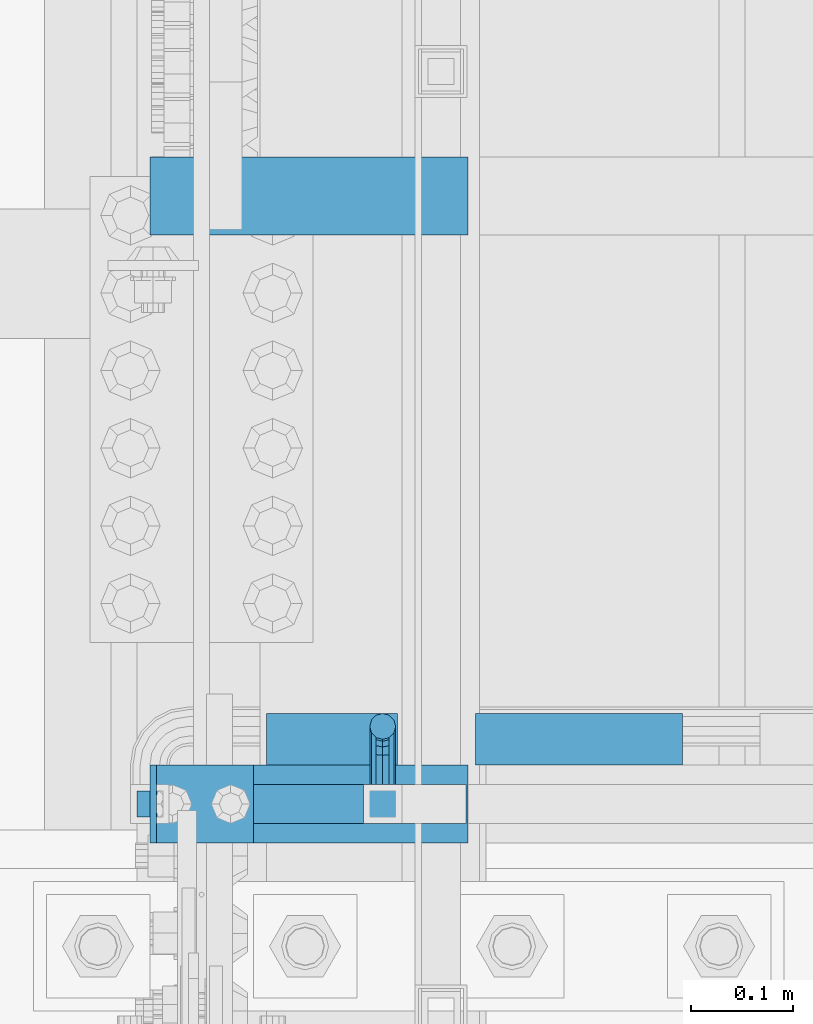
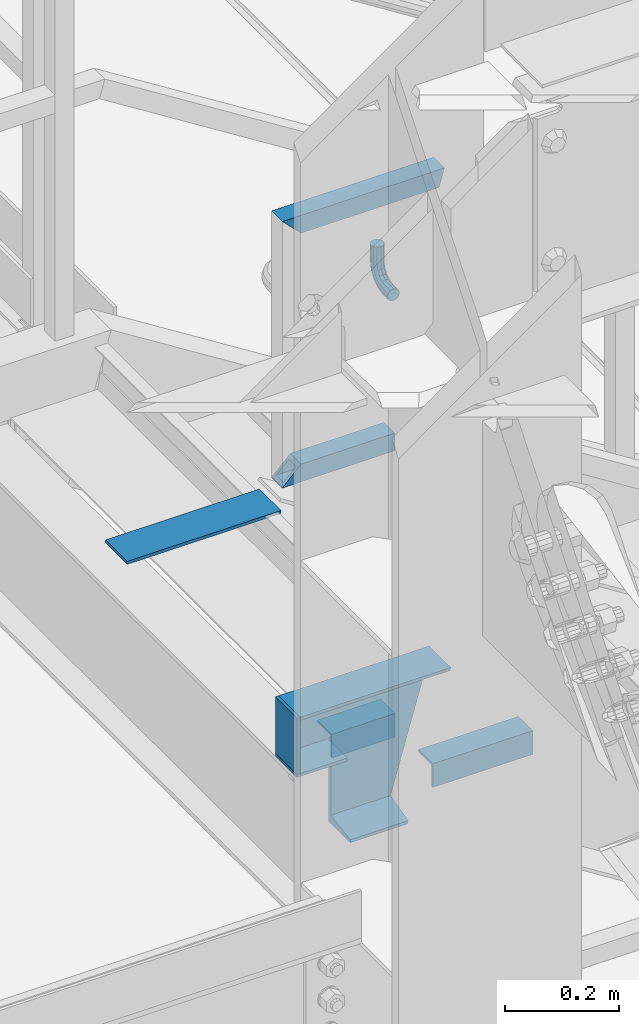
# One storey, part 2130 of 3843: 8 beams, 1 member, 3 elements without a shape of their own.
"""IFC2X3 building model written with IfcOpenShell, lengths in millimetres."""

from ifc_helpers import new_model, si_unit, frame, origin_with_axes, place, context, subcontext, project, spatial, faceted_brep, material, type_object, element, aggregate, save


model = new_model("IFC2X3")

# Units and contexts
model_context = context("Model", 3, precision=1e-05, world=origin_with_axes())
body_context = subcontext(model_context, "Body", "Model", "MODEL_VIEW")
ifc_project = project(units=[si_unit("LENGTHUNIT", "METRE", prefix="MILLI"), si_unit("AREAUNIT", "SQUARE_METRE"), si_unit("VOLUMEUNIT", "CUBIC_METRE"), si_unit("MASSUNIT", "GRAM", prefix="KILO"), si_unit("TIMEUNIT", "SECOND"), si_unit("PLANEANGLEUNIT", "RADIAN"), si_unit("SOLIDANGLEUNIT", "STERADIAN"), si_unit("THERMODYNAMICTEMPERATUREUNIT", "DEGREE_CELSIUS"), si_unit("LUMINOUSINTENSITYUNIT", "LUMEN")], contexts=[model_context])

# Site, building, storey
site_placement = place(None, origin_with_axes())
site = spatial("IfcSite", under=ifc_project, at=site_placement, CompositionType="ELEMENT")
building_placement = place(site_placement, origin_with_axes())
building = spatial("IfcBuilding", under=site, at=building_placement, Name="Undefined", CompositionType="ELEMENT")
storey_placement = place(building_placement, origin_with_axes())
storey = spatial("IfcBuildingStorey", under=building, at=storey_placement, Name="Undefined", CompositionType="ELEMENT", Elevation=0.0)

# Assembly, beams
assembly_1_placement = place(storey_placement, origin_with_axes())
assembly_1 = element("IfcElementAssembly", 1, at=assembly_1_placement, inside=storey, Name="RAIL", AssemblyPlace="NOTDEFINED", PredefinedType="RIGID_FRAME")
ifc_material_1 = material()
beam_type_1 = type_object("IfcBeamType", Name="HSS1-1/2X1-1/2X1/4", PredefinedType="NOTDEFINED")
beam_1_placement = place(assembly_1_placement, frame((56108.5999999675, 26060.40000005, 33832.8000002553), z_axis=(0.0, 0.0, 1.0), x_axis=(-1.0, 0.0, 0.0)))
beam_1 = element("IfcBeam", 2, at=beam_1_placement, type_object=beam_type_1, material=ifc_material_1, Name="RAIL", ObjectType="HSS1-1/2X1-1/2X1/4", context=body_context, shape_type="Brep", body=[
    faceted_brep([(19.0499992350015, -19.0499992350015, -19.0499992350015), (19.0499992350015, -19.0499992350015, 19.0499992350015), (19.0499992350015, 19.0499992350015, 19.0499992350015), (19.0499992350015, 19.0499992350015, -19.0499992350015), (19.0499992350015, 12.6999993299978, 12.6999993299978), (19.0499992350015, -12.6999993299978, 12.6999993299978), (19.0499992350015, -12.6999993299978, -12.6999993299978), (19.0499992350015, 12.6999993299978, -12.6999993299978), (247.649999996247, 19.0499992350015, -19.0499992350015), (247.649999996247, -19.0499992350015, -19.0499992350015), (209.550000745963, -19.0499992350015, 19.0499992356708), (209.550000745963, 19.0499992350015, 19.0499992356708), (215.900000654663, -12.6999993300014, 12.6999993306963), (215.900000654663, 12.6999993300014, 12.6999993306963), (241.299999329458, 12.6999993300014, -12.6999993292266), (241.299999329458, -12.6999993300014, -12.6999993292266)], [[[0, 1, 2, 3], [4, 5, 6, 7]], [[8, 9, 0, 3]], [[9, 10, 1, 0]], [[10, 11, 2, 1]], [[11, 8, 3, 2]], [[10, 9, 8, 11], [12, 13, 14, 15]], [[13, 12, 5, 4]], [[14, 13, 4, 7]], [[15, 14, 7, 6]], [[12, 15, 6, 5]]]),
])
beam_2_placement = place(assembly_1_placement, frame((55879.9999999675, 26060.40000005, 34366.2000000799), z_axis=(0.0, 0.0, -1.0), x_axis=(1.0, 0.0, 0.0)))
beam_2 = element("IfcBeam", 3, at=beam_2_placement, type_object=beam_type_1, material=ifc_material_1, Name="RAIL", ObjectType="HSS1-1/2X1-1/2X1/4", context=body_context, shape_type="Brep", body=[
    faceted_brep([(-12.6999993309546, 12.6999993299978, -12.6999993299978), (-12.6999993309546, -12.6999993299978, -12.6999993299978), (308.4703350696, -12.6999993300014, -12.6999993290228), (308.4703350696, 12.6999993300014, -12.6999993290228), (12.6999993290483, -12.6999993299978, 12.6999993299978), (301.129664099179, -12.6999993300014, 12.6999993309582), (12.6999993290483, 12.6999993299978, 12.6999993299978), (301.129664099179, 12.6999993300014, 12.6999993309582), (-19.0499992359546, 19.0499992350015, -19.0499992350015), (19.0499992350015, 19.0499992350015, 19.0499992350015), (299.294496287221, 19.0499992350015, 19.0499992359473), (310.305502881565, 19.0499992350015, -19.0499992340192), (19.0499992350015, -19.0499992350015, 19.0499992350015), (299.294496287221, -19.0499992350015, 19.0499992359473), (-19.0499992359546, -19.0499992350015, -19.0499992350015), (310.305502881565, -19.0499992350015, -19.0499992340192)], [[[0, 1, 2, 3]], [[1, 4, 5, 2]], [[4, 6, 7, 5]], [[6, 0, 3, 7]], [[8, 9, 10, 11]], [[9, 12, 13, 10]], [[12, 14, 15, 13]], [[14, 8, 11, 15]], [[13, 15, 11, 10], [5, 7, 3, 2]], [[14, 12, 9, 8], [6, 4, 1, 0]]]),
])

assembly_2_placement = place(storey_placement, origin_with_axes())
assembly_2 = element("IfcElementAssembly", 4, at=assembly_2_placement, inside=storey, Name="STAIR", AssemblyPlace="NOTDEFINED", PredefinedType="RIGID_FRAME")
ifc_material_2 = material(Name="STEEL/A36")
beam_type_2 = type_object("IfcBeamType", PredefinedType="NOTDEFINED")
beam_3_placement = place(assembly_2_placement, frame((55880.0, 26060.4, 33200.9749999995), z_axis=(0.0, 1.0, 0.0), x_axis=(1.0, 0.0, 0.0)))
beam_3 = element("IfcBeam", 5, at=beam_3_placement, type_object=beam_type_2, material=ifc_material_2, Name="PLATE", context=body_context, shape_type="Brep", body=[
    faceted_brep([(0.0, 3.17500000000291, -38.0999999999985), (0.0, 3.17500000000291, 38.0999999999985), (101.60000000002, 3.17500000000291, 38.0999999999985), (101.60000000002, 3.17500000000291, -38.0999999999985), (0.0, -3.17500000000291, 38.0999999999985), (101.60000000002, -3.17500000000291, 38.0999999999985), (0.0, -3.17500000000291, -38.0999999999985), (101.60000000002, -3.17500000000291, -38.0999999999985)], [[[0, 1, 2, 3]], [[1, 4, 5, 2]], [[4, 6, 7, 5]], [[6, 0, 3, 7]], [[5, 7, 3, 2]], [[6, 4, 1, 0]]]),
])
beam_4_placement = place(assembly_2_placement, frame((55883.175, 26060.4, 33324.8000000001), z_axis=(0.0, -1.0, 0.0), x_axis=(0.0, 0.0, -1.0)))
beam_4 = element("IfcBeam", 6, at=beam_4_placement, type_object=beam_type_2, material=ifc_material_2, Name="PLATE", context=body_context, shape_type="Brep", body=[
    faceted_brep([(0.0, 3.17500000000291, -38.0999999999985), (0.0, 3.17500000000291, 38.0999999999985), (120.650000000831, 3.17500000000291, 38.0999999999985), (120.650000000831, 3.17500000000291, -38.0999999999985), (0.0, -3.17500000000291, 38.0999999999985), (120.650000000831, -3.17500000000291, 38.0999999999985), (0.0, -3.17500000000291, -38.0999999999985), (120.650000000831, -3.17500000000291, -38.0999999999985)], [[[0, 1, 2, 3]], [[1, 4, 5, 2]], [[4, 6, 7, 5]], [[6, 0, 3, 7]], [[5, 7, 3, 2]], [[6, 4, 1, 0]]]),
])
beam_type_3 = type_object("IfcBeamType", Name="L2X2X3/16", PredefinedType="NOTDEFINED")
beam_5_placement = place(assembly_2_placement, frame((56122.8875000135, 26123.9000000667, 33178.7500000177), z_axis=(0.0, 1.0, 0.0), x_axis=(-1.0, 0.0, 0.0)))
beam_5 = element("IfcBeam", 7, at=beam_5_placement, type_object=beam_type_3, material=ifc_material_2, Name="ANGLE", ObjectType="L2X2X3/16", context=body_context, shape_type="Brep", body=[
    faceted_brep([(0.0, 25.4000000000015, -25.4000000000015), (0.0, 25.4000000000015, 25.4000000000015), (128.587500013549, 25.4000000000015, 25.4000000000015), (128.587500013549, 25.4000000000015, -25.4000000000015), (0.0, 20.6375000000007, 25.4000000000015), (128.587500013549, 20.6374999999971, 25.4000000000015), (0.0, 20.6375000000007, -20.6375000000007), (128.587500013549, 20.6374999999971, -20.6375000000007), (0.0, -25.4000000000015, -20.6375000000007), (128.587500013549, -25.4000000000015, -20.6375000000007), (0.0, -25.4000000000015, -25.4000000000015), (128.587500013549, -25.4000000000015, -25.4000000000015)], [[[0, 1, 2, 3]], [[1, 4, 5, 2]], [[4, 6, 7, 5]], [[6, 8, 9, 7]], [[8, 10, 11, 9]], [[10, 0, 3, 11]], [[5, 7, 9, 11, 3, 2]], [[10, 8, 6, 4, 1, 0]]]),
])
beam_6_placement = place(assembly_2_placement, frame((56402.8696627235, 26123.9000000611, 33043.812499978), z_axis=(0.0, 1.0, 0.0), x_axis=(-1.0, 0.0, 0.0)))
beam_6 = element("IfcBeam", 8, at=beam_6_placement, type_object=beam_type_3, material=ifc_material_2, Name="ANGLE", ObjectType="L2X2X3/16", context=body_context, shape_type="Brep", body=[
    faceted_brep([(0.0, 25.4000000000015, -25.4000000000015), (0.0, 25.4000000000015, 25.4000000000015), (203.199999999997, 25.4000000000015, 25.4000000000015), (203.199999999997, 25.4000000000015, -25.4000000000015), (0.0, 20.6375000000007, 25.4000000000015), (203.199999999997, 20.6375000000007, 25.4000000000015), (0.0, 20.6375000000007, -20.6375000000007), (203.199999999997, 20.6375000000007, -20.6375000000007), (0.0, -25.4000000000015, -20.6375000000007), (203.199999999997, -25.4000000000015, -20.6375000000007), (0.0, -25.4000000000015, -25.4000000000015), (203.199999999997, -25.4000000000015, -25.4000000000015)], [[[0, 1, 2, 3]], [[1, 4, 5, 2]], [[4, 6, 7, 5]], [[6, 8, 9, 7]], [[8, 10, 11, 9]], [[10, 0, 3, 11]], [[5, 7, 9, 11, 3, 2]], [[10, 8, 6, 4, 1, 0]]]),
])
beam_type_4 = type_object("IfcBeamType", Name="C12X20.7", PredefinedType="NOTDEFINED")
beam_7_placement = place(assembly_2_placement, frame((55879.9999999978, 26060.3999999826, 33172.4000000001), z_axis=(0.0, 0.0, 1.0), x_axis=(1.0, 0.0, 0.0)))
beam_7 = element("IfcBeam", 9, at=beam_7_placement, type_object=beam_type_4, material=ifc_material_2, Name="STAIR", ObjectType="C12X20.7", context=body_context, shape_type="Brep", body=[
    faceted_brep([(107.950000002187, 30.1624999999985, 31.749999999367), (107.950000002187, 38.0999999999985, 31.749999999367), (107.950000002187, 38.0999999999985, -152.400000000001), (107.950000002187, -38.0999999999985, -152.400000000001), (107.950000002187, -38.0999999999985, -146.047460000002), (107.950000002187, 30.1624999999985, -134.674927499997), (6.35000000218861, 30.1624999999985, 31.749999999367), (6.35000000218861, 38.0999999999985, 31.749999999367), (6.35000000000582, 38.0999999999985, 152.400000000001), (6.35000000218861, -38.0999999999985, 152.400000000001), (312.140671356683, -38.0999999999985, 152.400000000001), (312.140671356683, 38.0999999999985, 152.400000000001), (6.35000000218861, -38.0999999999985, 146.047460000002), (310.304769448485, -38.0999999999985, 146.047460000002), (6.35000000218861, 30.1624999999985, 134.674927499997), (307.018075603533, 30.1624999999985, 134.674927499997), (229.175210738853, 30.1624999999985, -134.674927499997), (225.888516893909, -38.0999999999985, -146.047460000002), (224.052614985711, -38.0999999999985, -152.400000000001), (224.052614985711, 38.0999999999985, -152.400000000001)], [[[0, 1, 2, 3, 4, 5]], [[6, 7, 1, 0]], [[8, 9, 10, 11]], [[9, 12, 13, 10]], [[12, 14, 15, 13]], [[10, 13, 15, 16, 17, 18, 19, 11]], [[17, 16, 5, 4]], [[18, 17, 4, 3]], [[19, 18, 3, 2]], [[8, 11, 19, 2, 1, 7]], [[14, 12, 9, 8, 7, 6]], [[16, 15, 14, 6, 0, 5]]]),
])
aggregate(assembly_2, [beam_5, beam_3, beam_4, beam_6, beam_7])

# Beam
beam_type_5 = type_object("IfcBeamType", PredefinedType="NOTDEFINED")
beam_8_placement = place(assembly_1_placement, frame((56108.6000003381, 26079.45000005, 34118.55), z_axis=(1.0, 0.0, 0.0), x_axis=(0.0, 1.0, 0.0)))
beam_8 = element("IfcBeam", 10, at=beam_8_placement, type_object=beam_type_5, material=ifc_material_2, Name="BRACKET ARM", context=body_context, shape_type="Brep", body=[
    faceted_brep([(0.0, -12.6999999999971, 0.0), (0.0, -10.9985226280696, -6.34999999999854), (19.0500015258731, -10.9985226280623, -6.34999999999854), (19.0500015258731, -12.6999999999971, -6.33008312433958e-10), (0.0, -6.35000000000582, -10.9985226280623), (19.0500015258731, -6.34999999999854, -10.9985226280623), (0.0, 0.0, -12.6999999999971), (19.0500015258731, 0.0, -12.6999999999971), (0.0, 6.35000000000582, -10.9985226280623), (19.0500015258731, 6.34999999999854, -10.9985226280623), (0.0, 10.9985226280696, -6.34999999999854), (19.0500015258731, 10.9985226280623, -6.34999999999854), (0.0, 12.6999999999971, 0.0), (19.0500015258731, 12.6999999999971, 0.0), (0.0, 10.9985226280696, 6.34999999999854), (19.0500015258731, 10.9985226280623, 6.34999999999854), (0.0, 6.35000000000582, 10.9985226280623), (19.0500015258731, 6.34999999999854, 10.9985226280623), (0.0, 0.0, 12.6999999999971), (19.0500015258731, 0.0, 12.6999999999971), (0.0, -6.35000000000582, 10.9985226280623), (19.0500015258731, -6.34999999999854, 10.9985226280623), (0.0, -10.9985226280696, 6.34999999999854), (19.0500015258731, -10.9985226280623, 6.34999999999854), (38.4903193060891, -8.8330803677236, -3.34694050252438e-10), (37.8391921052389, -7.26112024908798, 6.34999999974389), (36.0602795104642, -2.96644533684594, 10.9985226280041), (33.6302397149266, 2.90018969451194, 12.7000000002226), (31.2001999194181, 8.76682472604443, 10.9985226285644), (29.4212873247307, 13.061499638774, 6.35000000070431), (28.7701601240115, 14.6334597580644, 7.78527464717627e-10), (29.4212873248762, 13.0614996394288, -6.34999999929278), (31.2001999196509, 8.76682472718676, -10.9985226275603), (33.6302397151885, 2.90018969582889, -12.6999999997788), (36.0602795106824, -2.96644533571089, -10.9985226281206), (37.8391921053699, -7.26112024843314, -6.35000000026048), (53.7678987435793, 3.38210125690239, -6.3499999994383), (54.9710249311902, 2.17897506880399, 5.0931703299284e-10), (50.4808968708676, 6.66910312997061, -10.9985226273784), (45.9907688103704, 11.1592311906061, -12.6999999991458), (41.5006407498004, 15.6493592510378, -10.9985226270364), (38.213638876914, 18.9363611235749, -6.34999999884167), (37.0105126890558, 20.1394873109457, 1.20053300634027e-09), (38.2136388766667, 18.9363611228473, 6.35000000115542), (41.5006407493784, 15.6493592497718, 10.9985226290883), (45.9907688098756, 11.1592311891436, 12.7000000008557), (50.4808968704456, 6.66910312870459, 10.9985226287463), (53.7678987433319, 3.38210125617479, 6.35000000055879), (64.4111202489148, 19.3108078951118, -6.34999999821594), (65.9830803677178, 18.6596806939051, 1.77533365786076e-09), (60.1164453365491, 21.0897204901557, -10.9985226262725), (54.2498103051475, 23.5197602857806, -12.6999999981927), (48.3831752736587, 25.9498000811873, -10.9985226262434), (44.0885003610601, 27.7287126756128, -6.34999999817228), (42.516540241937, 28.3798398759754, 1.83354131877422e-09), (44.08850036074, 27.7287126747688, 6.35000000183209), (48.3831752731057, 25.9498000797321, 10.9985226298813), (54.2498103045073, 23.5197602840999, 12.7000000018088), (60.1164453359961, 21.0897204886933, 10.9985226298522), (64.4111202485947, 19.3108078942678, 6.35000000178115), (68.1485226282239, 38.0999984746086, -6.3499999967753), (69.8499999999913, 38.0999984741211, 2.92493496090174e-09), (63.500000000291, 38.0999984749651, -10.9985226249628), (57.1500000003434, 38.0999984750961, -12.6999999970722), (50.8000000002939, 38.0999984749651, -10.998522625312), (46.1514773720992, 38.0999984746086, -6.34999999737192), (44.4499999999971, 38.0999984741211, 2.58296495303512e-09), (46.1514773717645, 38.0999984736336, 6.35000000262517), (50.7999999996973, 38.0999984732771, 10.9985226308127), (57.1499999996449, 38.0999984731461, 12.700000002922), (63.4999999996944, 38.0999984732771, 10.9985226311619), (68.1485226278892, 38.0999984736336, 6.35000000322179), (68.1485226280638, 76.2000000002372, -6.34999999414867), (69.8499999999913, 76.199999999757, 5.84986992180347e-09), (63.5, 76.200000000601, -10.9985226222125), (57.1499999999942, 76.2000000007247, -12.6999999941472), (50.7999999999884, 76.200000000601, -10.9985226222125), (46.1514773719246, 76.2000000002372, -6.34999999414867), (44.4499999999971, 76.199999999757, 5.84986992180347e-09), (46.1514773719246, 76.1999999992695, 6.35000000584841), (50.7999999999884, 76.1999999989057, 10.9985226339122), (57.1499999999942, 76.199999998782, 12.700000005847), (63.5, 76.1999999989057, 10.9985226339122), (68.1485226280638, 76.1999999992695, 6.35000000584841)], [[[0, 1, 2, 3]], [[1, 4, 5, 2]], [[4, 6, 7, 5]], [[6, 8, 9, 7]], [[8, 10, 11, 9]], [[10, 12, 13, 11]], [[12, 14, 15, 13]], [[14, 16, 17, 15]], [[16, 18, 19, 17]], [[18, 20, 21, 19]], [[20, 22, 23, 21]], [[22, 0, 3, 23]], [[22, 20, 18, 16, 14, 12, 10, 8, 6, 4, 1, 0]], [[23, 3, 24, 25]], [[21, 23, 25, 26]], [[19, 21, 26, 27]], [[17, 19, 27, 28]], [[15, 17, 28, 29]], [[13, 15, 29, 30]], [[11, 13, 30, 31]], [[9, 11, 31, 32]], [[7, 9, 32, 33]], [[5, 7, 33, 34]], [[2, 5, 34, 35]], [[3, 2, 35, 24]], [[35, 36, 37, 24]], [[34, 38, 36, 35]], [[33, 39, 38, 34]], [[32, 40, 39, 33]], [[31, 41, 40, 32]], [[30, 42, 41, 31]], [[29, 43, 42, 30]], [[28, 44, 43, 29]], [[27, 45, 44, 28]], [[26, 46, 45, 27]], [[25, 47, 46, 26]], [[24, 37, 47, 25]], [[36, 48, 49, 37]], [[38, 50, 48, 36]], [[39, 51, 50, 38]], [[40, 52, 51, 39]], [[41, 53, 52, 40]], [[42, 54, 53, 41]], [[43, 55, 54, 42]], [[44, 56, 55, 43]], [[45, 57, 56, 44]], [[46, 58, 57, 45]], [[47, 59, 58, 46]], [[37, 49, 59, 47]], [[48, 60, 61, 49]], [[50, 62, 60, 48]], [[51, 63, 62, 50]], [[52, 64, 63, 51]], [[53, 65, 64, 52]], [[54, 66, 65, 53]], [[55, 67, 66, 54]], [[56, 68, 67, 55]], [[57, 69, 68, 56]], [[58, 70, 69, 57]], [[59, 71, 70, 58]], [[49, 61, 71, 59]], [[61, 60, 72, 73]], [[60, 62, 74, 72]], [[62, 63, 75, 74]], [[63, 64, 76, 75]], [[64, 65, 77, 76]], [[65, 66, 78, 77]], [[66, 67, 79, 78]], [[67, 68, 80, 79]], [[68, 69, 81, 80]], [[69, 70, 82, 81]], [[70, 71, 83, 82]], [[71, 61, 73, 83]], [[74, 75, 76, 77, 78, 79, 80, 81, 82, 83, 73, 72]]]),
])

aggregate(assembly_1, [beam_8, beam_1, beam_2])

# Assembly, member
assembly_3_placement = place(storey_placement, origin_with_axes())
assembly_3 = element("IfcElementAssembly", 11, at=assembly_3_placement, inside=storey, Name="ref.", AssemblyPlace="NOTDEFINED", PredefinedType="RIGID_FRAME")
ifc_material_3 = material(Name="STEEL/Steel_Undefined")
member_type = type_object("IfcMemberType", PredefinedType="NOTDEFINED")
member_placement = place(assembly_3_placement, frame((56192.1406715359, 26657.30000005, 33296.2250002668), z_axis=(0.0, -1.0, 0.0), x_axis=(-1.0, 0.0, 0.0)))
member = element("IfcMember", 12, at=member_placement, type_object=member_type, material=ifc_material_3, Name="ref.", context=body_context, shape_type="Brep", body=[
    faceted_brep([(0.0, 3.17500000000291, -38.0999999999985), (0.0, 3.17500000000291, 38.0999999999985), (312.140671533212, 3.1749999990061, 38.0999999999985), (312.140671533212, 3.1749999990061, -38.0999999999985), (0.0, -3.17500000000291, 38.0999999999985), (312.14067153319, -3.17500000099244, 38.0999999999985), (0.0, -3.17500000000291, -38.0999999999985), (312.14067153319, -3.17500000099244, -38.0999999999985)], [[[0, 1, 2, 3]], [[1, 4, 5, 2]], [[4, 6, 7, 5]], [[6, 0, 3, 7]], [[5, 7, 3, 2]], [[6, 4, 1, 0]]]),
])
aggregate(assembly_3, [member])

save(model, "model.ifc")
